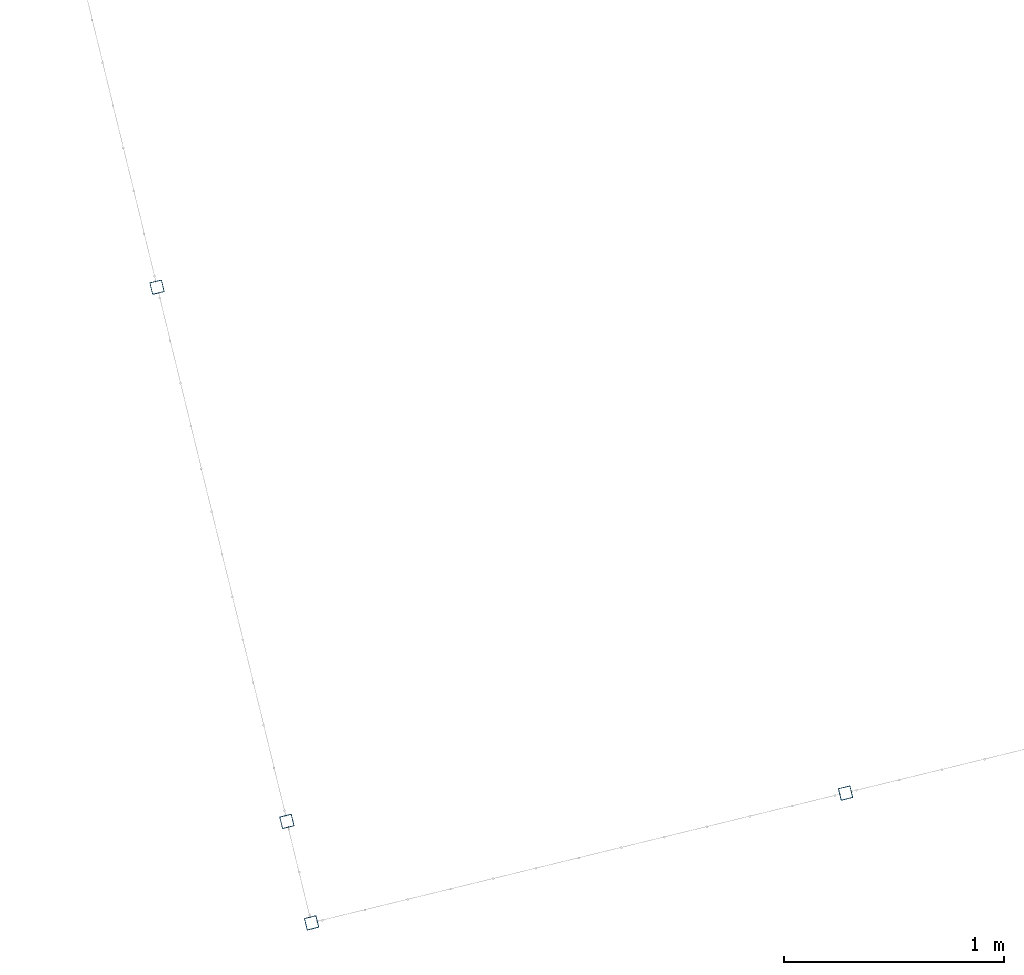
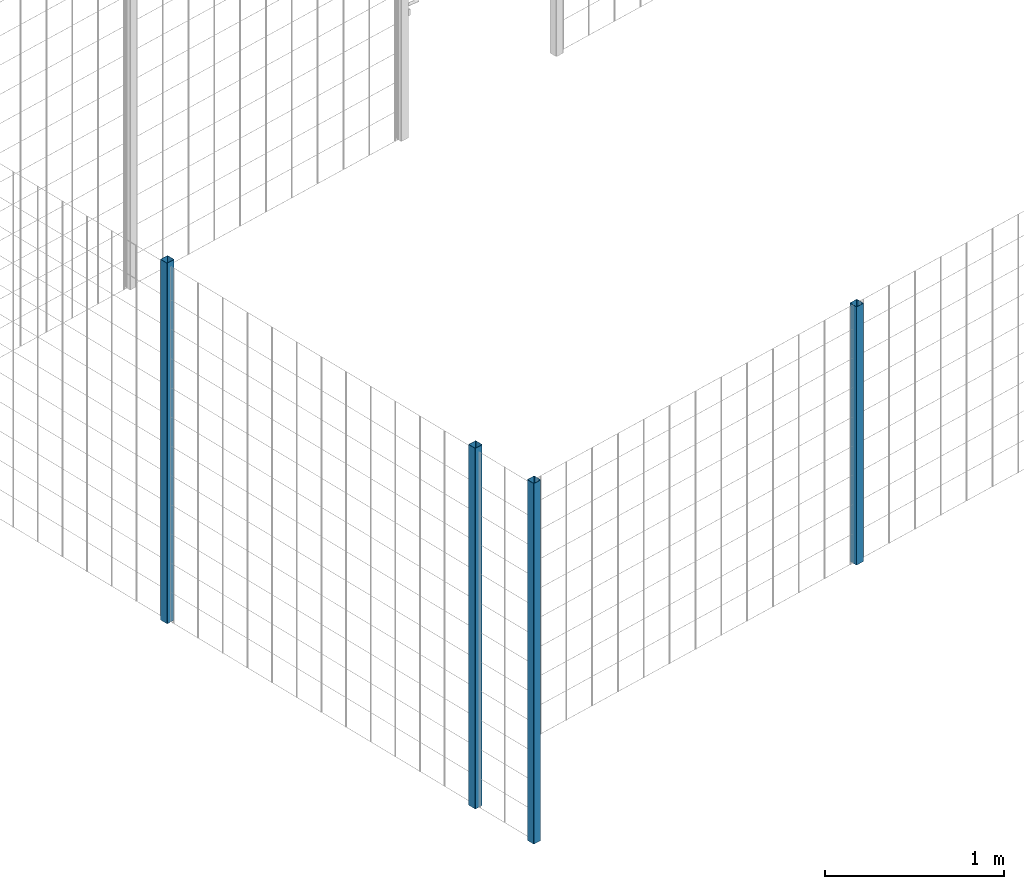
# One storey, part 1 of 10: 4 beams.
"""IFC2X3 building model written with IfcOpenShell, lengths in millimetres."""

from ifc_helpers import new_model, entity, si_unit, converted_unit, derived_unit, direction, frame, frame_2d, origin, place, context, subcontext, project, spatial, polyline, circle_curve, parameter, trimmed, segment, composite_curve, outline, extrude, material, type_object, element, save


model = new_model("IFC2X3")

# Units and contexts
model_context = context("Model", 3, precision=0.01, world=origin(), true_north=direction((6.12303176911189e-17, 1.0)))
body_context = subcontext(model_context, "Body", "Model", "MODEL_VIEW")
ifc_project = project(units=[si_unit("LENGTHUNIT", "METRE", prefix="MILLI"), si_unit("AREAUNIT", "SQUARE_METRE"), si_unit("VOLUMEUNIT", "CUBIC_METRE"), converted_unit("PLANEANGLEUNIT", "DEGREE", entity("IfcRatioMeasure", 0.0174532925199433), si_unit("PLANEANGLEUNIT", "RADIAN"), dimensions=[0, 0, 0, 0, 0, 0, 0]), si_unit("MASSUNIT", "GRAM", prefix="KILO"), derived_unit("MASSDENSITYUNIT", [(si_unit("MASSUNIT", "GRAM", prefix="KILO"), 1), (si_unit("LENGTHUNIT", "METRE"), -3)]), derived_unit("MOMENTOFINERTIAUNIT", [(si_unit("LENGTHUNIT", "METRE"), 4)]), si_unit("TIMEUNIT", "SECOND"), si_unit("FREQUENCYUNIT", "HERTZ"), si_unit("THERMODYNAMICTEMPERATUREUNIT", "DEGREE_CELSIUS"), derived_unit("THERMALTRANSMITTANCEUNIT", [(si_unit("MASSUNIT", "GRAM", prefix="KILO"), 1), (si_unit("THERMODYNAMICTEMPERATUREUNIT", "KELVIN"), -1), (si_unit("TIMEUNIT", "SECOND"), -3)]), derived_unit("VOLUMETRICFLOWRATEUNIT", [(si_unit("LENGTHUNIT", "METRE"), 3), (si_unit("TIMEUNIT", "SECOND"), -1)]), derived_unit("MASSFLOWRATEUNIT", [(si_unit("MASSUNIT", "GRAM", prefix="KILO"), 1), (si_unit("TIMEUNIT", "SECOND"), -1)]), derived_unit("ROTATIONALFREQUENCYUNIT", [(si_unit("TIMEUNIT", "SECOND"), -1)]), si_unit("ELECTRICCURRENTUNIT", "AMPERE"), si_unit("ELECTRICVOLTAGEUNIT", "VOLT"), si_unit("POWERUNIT", "WATT"), si_unit("FORCEUNIT", "NEWTON", prefix="KILO"), si_unit("ILLUMINANCEUNIT", "LUX"), si_unit("LUMINOUSFLUXUNIT", "LUMEN"), si_unit("LUMINOUSINTENSITYUNIT", "CANDELA"), derived_unit("USERDEFINED", [(si_unit("MASSUNIT", "GRAM", prefix="KILO"), -1), (si_unit("LENGTHUNIT", "METRE"), -2), (si_unit("TIMEUNIT", "SECOND"), 3), (si_unit("LUMINOUSFLUXUNIT", "LUMEN"), 1)]), derived_unit("LINEARVELOCITYUNIT", [(si_unit("LENGTHUNIT", "METRE"), 1), (si_unit("TIMEUNIT", "SECOND"), -1)]), si_unit("PRESSUREUNIT", "PASCAL"), derived_unit("USERDEFINED", [(si_unit("LENGTHUNIT", "METRE"), -2), (si_unit("MASSUNIT", "GRAM", prefix="KILO"), 1), (si_unit("TIMEUNIT", "SECOND"), -2)]), derived_unit("LINEARFORCEUNIT", [(si_unit("MASSUNIT", "GRAM", prefix="KILO"), 1), (si_unit("LENGTHUNIT", "METRE"), 1), (si_unit("TIMEUNIT", "SECOND"), -2), (si_unit("LENGTHUNIT", "METRE"), -1)]), derived_unit("PLANARFORCEUNIT", [(si_unit("MASSUNIT", "GRAM", prefix="KILO"), 1), (si_unit("LENGTHUNIT", "METRE"), 1), (si_unit("TIMEUNIT", "SECOND"), -2), (si_unit("LENGTHUNIT", "METRE"), -2)])], contexts=[model_context])

# Site, building, storey
site_placement = place(None, frame((19171.75, -72498.58, 0.0), z_axis=(0.0, 0.0, 1.0), x_axis=(0.971695960795463, 0.236234967296933, 0.0)))
site = spatial("IfcSite", under=ifc_project, at=site_placement, CompositionType="ELEMENT")
building_placement = place(site_placement, origin())
building = spatial("IfcBuilding", under=site, at=building_placement, CompositionType="ELEMENT")
storey_placement = place(building_placement, origin())
storey = spatial("IfcBuildingStorey", under=building, at=storey_placement, Name="01", CompositionType="ELEMENT", Elevation=0.0)

# Beams
ifc_material = material(Name="345")
beam_type = type_object("IfcBeamType", PredefinedType="NOTDEFINED")
beam_1_placement = place(storey_placement, frame((2669.77, 95.9, 699.02), z_axis=(1.0, 0.0, 0.0), x_axis=(0.0, 0.0, 1.0)))
element("IfcBeam", 1, at=beam_1_placement, inside=storey, type_object=beam_type, material=ifc_material, context=body_context, shape_type="SweptSolid", body=[
    extrude(outline(composite_curve([segment(trimmed(circle_curve(frame_2d((24.7, -24.7), x_axis=(1.0, 0.0)), 2.79999999999974), [parameter(269.999999999999)], [parameter(1.32311074748882e-12)], True, "PARAMETER"), True, "CONTINUOUS"), segment(polyline([(27.5, -24.7), (27.5, 24.7)]), True, "CONTINUOUS"), segment(trimmed(circle_curve(frame_2d((24.7, 24.7), x_axis=(1.0, 0.0)), 2.79999999999845), [parameter(1.32311074748882e-12)], [parameter(90.0000000000001)], True, "PARAMETER"), True, "CONTINUOUS"), segment(polyline([(24.7, 27.5), (-24.7, 27.5)]), True, "CONTINUOUS"), segment(trimmed(circle_curve(frame_2d((-24.7, 24.7), x_axis=(1.0, 0.0)), 2.79999999999845), [parameter(90.0000000000001)], [parameter(180.0)], True, "PARAMETER"), True, "CONTINUOUS"), segment(polyline([(-27.5, 24.7), (-27.5, -24.7)]), True, "CONTINUOUS"), segment(trimmed(circle_curve(frame_2d((-24.7, -24.7), x_axis=(1.0, 0.0)), 2.79999999999845), [parameter(180.0)], [parameter(269.999999999998)], True, "PARAMETER"), True, "CONTINUOUS"), segment(polyline([(-24.7, -27.5), (24.7, -27.5)]), True, "CONTINUOUS")], self_intersect=False), holes=[composite_curve([segment(polyline([(23.3, -26.1), (-23.3, -26.1)]), True, "CONTINUOUS"), segment(trimmed(circle_curve(frame_2d((-23.3, -23.3), x_axis=(1.0, 0.0)), 2.79999999999973), [parameter(180.0)], [parameter(270.0)], True, "PARAMETER"), False, "CONTINUOUS"), segment(polyline([(-26.1, -23.3), (-26.1, 23.3)]), True, "CONTINUOUS"), segment(trimmed(circle_curve(frame_2d((-23.3, 23.3), x_axis=(1.0, 0.0)), 2.79999999999973), [parameter(90.0000000000004)], [parameter(180.0)], True, "PARAMETER"), False, "CONTINUOUS"), segment(polyline([(-23.3, 26.1), (23.3, 26.1)]), True, "CONTINUOUS"), segment(trimmed(circle_curve(frame_2d((23.3, 23.3), x_axis=(1.0, 0.0)), 2.79999999999973), [parameter(3.56222124323914e-13)], [parameter(90.0000000000004)], True, "PARAMETER"), False, "CONTINUOUS"), segment(polyline([(26.1, 23.3), (26.1, -23.3)]), True, "CONTINUOUS"), segment(trimmed(circle_curve(frame_2d((23.3, -23.3), x_axis=(1.0, 0.0)), 2.80000000000034), [parameter(270.0)], [parameter(4.57999874130747e-13)], True, "PARAMETER"), False, "CONTINUOUS")], self_intersect=False)]), frame((0.0, -29.1, 29.1), z_axis=(1.0, 0.0, 0.0), x_axis=(0.0, -1.0, 0.0)), (0.0, 0.0, 1.0), 1765.97922445826),
])
beam_2_placement = place(storey_placement, frame((170.9, 95.9, -0.98), z_axis=(1.0, 0.0, 0.0), x_axis=(0.0, 0.0, 1.0)))
element("IfcBeam", 2, at=beam_2_placement, inside=storey, type_object=beam_type, material=ifc_material, context=body_context, shape_type="SweptSolid", body=[
    extrude(outline(composite_curve([segment(trimmed(circle_curve(frame_2d((24.7, -24.7), x_axis=(1.0, 0.0)), 2.79999999999974), [parameter(269.999999999999)], [parameter(1.32311074748882e-12)], True, "PARAMETER"), True, "CONTINUOUS"), segment(polyline([(27.5, -24.7), (27.5, 24.7)]), True, "CONTINUOUS"), segment(trimmed(circle_curve(frame_2d((24.7, 24.7), x_axis=(1.0, 0.0)), 2.79999999999845), [parameter(1.32311074748882e-12)], [parameter(90.0000000000001)], True, "PARAMETER"), True, "CONTINUOUS"), segment(polyline([(24.7, 27.5), (-24.7, 27.5)]), True, "CONTINUOUS"), segment(trimmed(circle_curve(frame_2d((-24.7, 24.7), x_axis=(1.0, 0.0)), 2.79999999999845), [parameter(90.0000000000001)], [parameter(180.0)], True, "PARAMETER"), True, "CONTINUOUS"), segment(polyline([(-27.5, 24.7), (-27.5, -24.7)]), True, "CONTINUOUS"), segment(trimmed(circle_curve(frame_2d((-24.7, -24.7), x_axis=(1.0, 0.0)), 2.79999999999845), [parameter(180.0)], [parameter(269.999999999998)], True, "PARAMETER"), True, "CONTINUOUS"), segment(polyline([(-24.7, -27.5), (24.7, -27.5)]), True, "CONTINUOUS")], self_intersect=False), holes=[composite_curve([segment(polyline([(23.3, -26.1), (-23.3, -26.1)]), True, "CONTINUOUS"), segment(trimmed(circle_curve(frame_2d((-23.3, -23.3), x_axis=(1.0, 0.0)), 2.79999999999973), [parameter(180.0)], [parameter(270.0)], True, "PARAMETER"), False, "CONTINUOUS"), segment(polyline([(-26.1, -23.3), (-26.1, 23.3)]), True, "CONTINUOUS"), segment(trimmed(circle_curve(frame_2d((-23.3, 23.3), x_axis=(1.0, 0.0)), 2.79999999999973), [parameter(90.0000000000004)], [parameter(180.0)], True, "PARAMETER"), False, "CONTINUOUS"), segment(polyline([(-23.3, 26.1), (23.3, 26.1)]), True, "CONTINUOUS"), segment(trimmed(circle_curve(frame_2d((23.3, 23.3), x_axis=(1.0, 0.0)), 2.79999999999973), [parameter(3.56222124323914e-13)], [parameter(90.0000000000004)], True, "PARAMETER"), False, "CONTINUOUS"), segment(polyline([(26.1, 23.3), (26.1, -23.3)]), True, "CONTINUOUS"), segment(trimmed(circle_curve(frame_2d((23.3, -23.3), x_axis=(1.0, 0.0)), 2.80000000000034), [parameter(270.0)], [parameter(4.57999874130747e-13)], True, "PARAMETER"), False, "CONTINUOUS")], self_intersect=False)]), frame((0.0, -29.1, 29.1), z_axis=(1.0, 0.0, 0.0), x_axis=(0.0, -1.0, 0.0)), (0.0, 0.0, 1.0), 2465.97922445826),
])
beam_3_placement = place(storey_placement, frame((170.9, 570.9, -0.98), z_axis=(1.0, 0.0, 0.0), x_axis=(0.0, 0.0, 1.0)))
element("IfcBeam", 3, at=beam_3_placement, inside=storey, type_object=beam_type, material=ifc_material, context=body_context, shape_type="SweptSolid", body=[
    extrude(outline(composite_curve([segment(trimmed(circle_curve(frame_2d((24.7, -24.7), x_axis=(1.0, 0.0)), 2.79999999999974), [parameter(269.999999999999)], [parameter(1.32311074748882e-12)], True, "PARAMETER"), True, "CONTINUOUS"), segment(polyline([(27.5, -24.7), (27.5, 24.7)]), True, "CONTINUOUS"), segment(trimmed(circle_curve(frame_2d((24.7, 24.7), x_axis=(1.0, 0.0)), 2.79999999999845), [parameter(1.32311074748882e-12)], [parameter(90.0000000000001)], True, "PARAMETER"), True, "CONTINUOUS"), segment(polyline([(24.7, 27.5), (-24.7, 27.5)]), True, "CONTINUOUS"), segment(trimmed(circle_curve(frame_2d((-24.7, 24.7), x_axis=(1.0, 0.0)), 2.79999999999845), [parameter(90.0000000000001)], [parameter(180.0)], True, "PARAMETER"), True, "CONTINUOUS"), segment(polyline([(-27.5, 24.7), (-27.5, -24.7)]), True, "CONTINUOUS"), segment(trimmed(circle_curve(frame_2d((-24.7, -24.7), x_axis=(1.0, 0.0)), 2.79999999999845), [parameter(180.0)], [parameter(269.999999999998)], True, "PARAMETER"), True, "CONTINUOUS"), segment(polyline([(-24.7, -27.5), (24.7, -27.5)]), True, "CONTINUOUS")], self_intersect=False), holes=[composite_curve([segment(polyline([(23.3, -26.1), (-23.3, -26.1)]), True, "CONTINUOUS"), segment(trimmed(circle_curve(frame_2d((-23.3, -23.3), x_axis=(1.0, 0.0)), 2.79999999999973), [parameter(180.0)], [parameter(270.0)], True, "PARAMETER"), False, "CONTINUOUS"), segment(polyline([(-26.1, -23.3), (-26.1, 23.3)]), True, "CONTINUOUS"), segment(trimmed(circle_curve(frame_2d((-23.3, 23.3), x_axis=(1.0, 0.0)), 2.79999999999973), [parameter(90.0000000000004)], [parameter(180.0)], True, "PARAMETER"), False, "CONTINUOUS"), segment(polyline([(-23.3, 26.1), (23.3, 26.1)]), True, "CONTINUOUS"), segment(trimmed(circle_curve(frame_2d((23.3, 23.3), x_axis=(1.0, 0.0)), 2.79999999999973), [parameter(3.56222124323914e-13)], [parameter(90.0000000000004)], True, "PARAMETER"), False, "CONTINUOUS"), segment(polyline([(26.1, 23.3), (26.1, -23.3)]), True, "CONTINUOUS"), segment(trimmed(circle_curve(frame_2d((23.3, -23.3), x_axis=(1.0, 0.0)), 2.80000000000034), [parameter(270.0)], [parameter(4.57999874130747e-13)], True, "PARAMETER"), False, "CONTINUOUS")], self_intersect=False)]), frame((0.0, -29.1, 29.1), z_axis=(1.0, 0.0, 0.0), x_axis=(0.0, -1.0, 0.0)), (0.0, 0.0, 1.0), 2465.97922445826),
])
beam_4_placement = place(storey_placement, frame((170.9, 3070.9, -0.98), z_axis=(1.0, 0.0, 0.0), x_axis=(0.0, 0.0, 1.0)))
element("IfcBeam", 4, at=beam_4_placement, inside=storey, type_object=beam_type, material=ifc_material, context=body_context, shape_type="SweptSolid", body=[
    extrude(outline(composite_curve([segment(trimmed(circle_curve(frame_2d((24.7, -24.7), x_axis=(1.0, 0.0)), 2.79999999999974), [parameter(269.999999999999)], [parameter(1.32311074748882e-12)], True, "PARAMETER"), True, "CONTINUOUS"), segment(polyline([(27.5, -24.7), (27.5, 24.7)]), True, "CONTINUOUS"), segment(trimmed(circle_curve(frame_2d((24.7, 24.7), x_axis=(1.0, 0.0)), 2.79999999999845), [parameter(1.32311074748882e-12)], [parameter(90.0000000000001)], True, "PARAMETER"), True, "CONTINUOUS"), segment(polyline([(24.7, 27.5), (-24.7, 27.5)]), True, "CONTINUOUS"), segment(trimmed(circle_curve(frame_2d((-24.7, 24.7), x_axis=(1.0, 0.0)), 2.79999999999845), [parameter(90.0000000000001)], [parameter(180.0)], True, "PARAMETER"), True, "CONTINUOUS"), segment(polyline([(-27.5, 24.7), (-27.5, -24.7)]), True, "CONTINUOUS"), segment(trimmed(circle_curve(frame_2d((-24.7, -24.7), x_axis=(1.0, 0.0)), 2.79999999999845), [parameter(180.0)], [parameter(269.999999999998)], True, "PARAMETER"), True, "CONTINUOUS"), segment(polyline([(-24.7, -27.5), (24.7, -27.5)]), True, "CONTINUOUS")], self_intersect=False), holes=[composite_curve([segment(polyline([(23.3, -26.1), (-23.3, -26.1)]), True, "CONTINUOUS"), segment(trimmed(circle_curve(frame_2d((-23.3, -23.3), x_axis=(1.0, 0.0)), 2.79999999999973), [parameter(180.0)], [parameter(270.0)], True, "PARAMETER"), False, "CONTINUOUS"), segment(polyline([(-26.1, -23.3), (-26.1, 23.3)]), True, "CONTINUOUS"), segment(trimmed(circle_curve(frame_2d((-23.3, 23.3), x_axis=(1.0, 0.0)), 2.79999999999973), [parameter(90.0000000000004)], [parameter(180.0)], True, "PARAMETER"), False, "CONTINUOUS"), segment(polyline([(-23.3, 26.1), (23.3, 26.1)]), True, "CONTINUOUS"), segment(trimmed(circle_curve(frame_2d((23.3, 23.3), x_axis=(1.0, 0.0)), 2.79999999999973), [parameter(3.56222124323914e-13)], [parameter(90.0000000000004)], True, "PARAMETER"), False, "CONTINUOUS"), segment(polyline([(26.1, 23.3), (26.1, -23.3)]), True, "CONTINUOUS"), segment(trimmed(circle_curve(frame_2d((23.3, -23.3), x_axis=(1.0, 0.0)), 2.80000000000034), [parameter(270.0)], [parameter(4.57999874130747e-13)], True, "PARAMETER"), False, "CONTINUOUS")], self_intersect=False)]), frame((0.0, -29.1, 29.1), z_axis=(1.0, 0.0, 0.0), x_axis=(0.0, -1.0, 0.0)), (0.0, 0.0, 1.0), 2465.97922445826),
])

save(model, "model.ifc")
